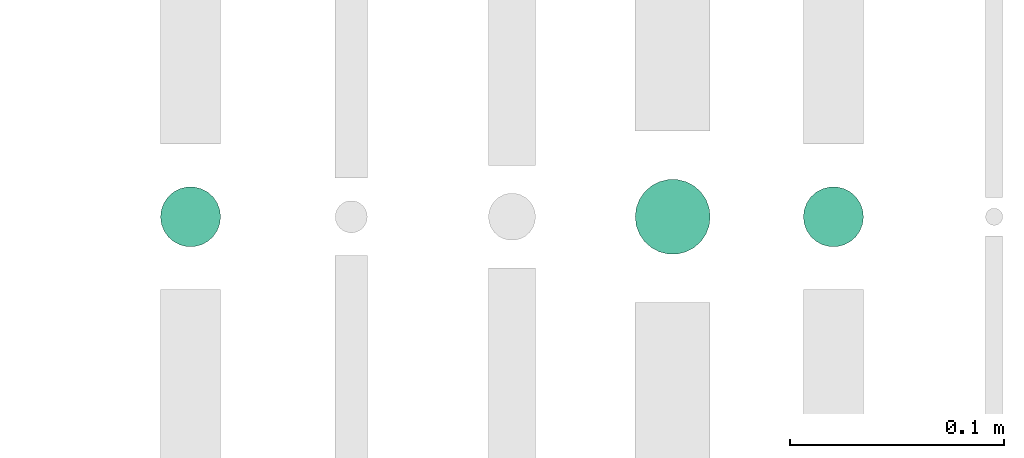
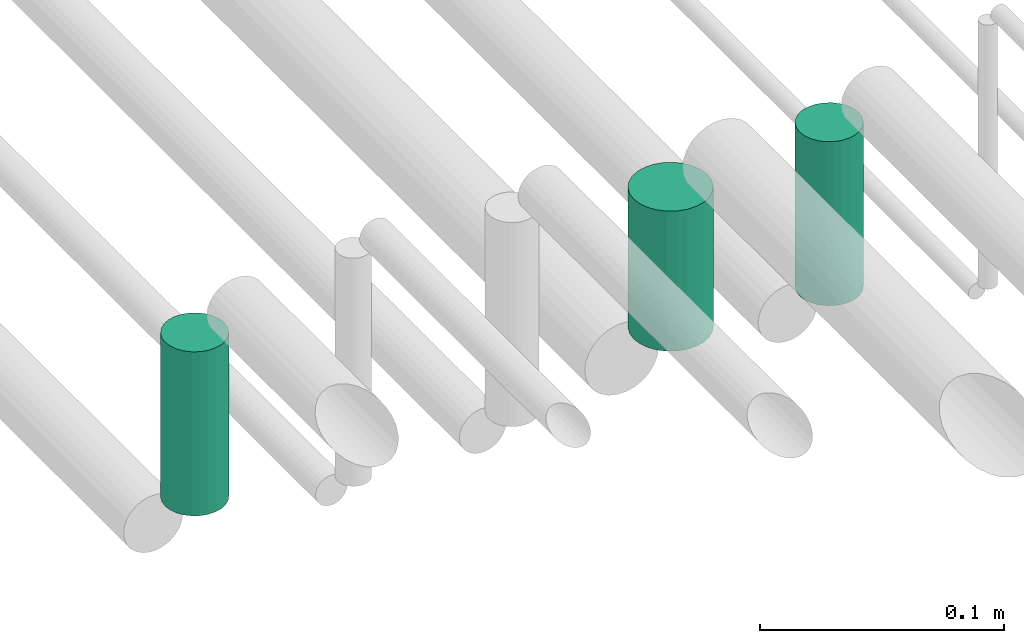
# One storey, part 289 of 331: 3 flow segments.
"""IFC2X3 building model written with IfcOpenShell, lengths in millimetres."""

from ifc_helpers import new_model, entity, si_unit, converted_unit, derived_unit, direction, frame, origin, origin_2d_with_axis, place, context, subcontext, project, spatial, circle, extrude, type_object, element, save


model = new_model("IFC2X3")

# Units and contexts
model_context = context("Model", 3, precision=0.01, world=origin(), true_north=direction((6.12303176911189e-17, 1.0)))
body_context = subcontext(model_context, "Body", "Model", "MODEL_VIEW")
ifc_project = project(units=[si_unit("LENGTHUNIT", "METRE", prefix="MILLI"), si_unit("AREAUNIT", "SQUARE_METRE"), si_unit("VOLUMEUNIT", "CUBIC_METRE"), converted_unit("PLANEANGLEUNIT", "DEGREE", entity("IfcRatioMeasure", 0.0174532925199433), si_unit("PLANEANGLEUNIT", "RADIAN"), dimensions=[0, 0, 0, 0, 0, 0, 0]), si_unit("MASSUNIT", "GRAM", prefix="KILO"), derived_unit("MASSDENSITYUNIT", [(si_unit("MASSUNIT", "GRAM", prefix="KILO"), 1), (si_unit("LENGTHUNIT", "METRE"), -3)]), derived_unit("MOMENTOFINERTIAUNIT", [(si_unit("LENGTHUNIT", "METRE"), 4)]), si_unit("TIMEUNIT", "SECOND"), si_unit("FREQUENCYUNIT", "HERTZ"), si_unit("THERMODYNAMICTEMPERATUREUNIT", "DEGREE_CELSIUS"), derived_unit("THERMALTRANSMITTANCEUNIT", [(si_unit("MASSUNIT", "GRAM", prefix="KILO"), 1), (si_unit("THERMODYNAMICTEMPERATUREUNIT", "KELVIN"), -1), (si_unit("TIMEUNIT", "SECOND"), -3)]), derived_unit("VOLUMETRICFLOWRATEUNIT", [(si_unit("LENGTHUNIT", "METRE"), 3), (si_unit("TIMEUNIT", "SECOND"), -1)]), derived_unit("MASSFLOWRATEUNIT", [(si_unit("MASSUNIT", "GRAM", prefix="KILO"), 1), (si_unit("TIMEUNIT", "SECOND"), -1)]), derived_unit("ROTATIONALFREQUENCYUNIT", [(si_unit("TIMEUNIT", "SECOND"), -1)]), si_unit("ELECTRICCURRENTUNIT", "AMPERE"), si_unit("ELECTRICVOLTAGEUNIT", "VOLT"), si_unit("POWERUNIT", "WATT"), si_unit("FORCEUNIT", "NEWTON", prefix="KILO"), si_unit("ILLUMINANCEUNIT", "LUX"), si_unit("LUMINOUSFLUXUNIT", "LUMEN"), si_unit("LUMINOUSINTENSITYUNIT", "CANDELA"), derived_unit("USERDEFINED", [(si_unit("MASSUNIT", "GRAM", prefix="KILO"), -1), (si_unit("LENGTHUNIT", "METRE"), -2), (si_unit("TIMEUNIT", "SECOND"), 3), (si_unit("LUMINOUSFLUXUNIT", "LUMEN"), 1)]), derived_unit("LINEARVELOCITYUNIT", [(si_unit("LENGTHUNIT", "METRE"), 1), (si_unit("TIMEUNIT", "SECOND"), -1)]), si_unit("PRESSUREUNIT", "PASCAL"), derived_unit("USERDEFINED", [(si_unit("LENGTHUNIT", "METRE"), -2), (si_unit("MASSUNIT", "GRAM", prefix="KILO"), 1), (si_unit("TIMEUNIT", "SECOND"), -2)]), derived_unit("LINEARFORCEUNIT", [(si_unit("MASSUNIT", "GRAM", prefix="KILO"), 1), (si_unit("LENGTHUNIT", "METRE"), 1), (si_unit("TIMEUNIT", "SECOND"), -2), (si_unit("LENGTHUNIT", "METRE"), -1)]), derived_unit("PLANARFORCEUNIT", [(si_unit("MASSUNIT", "GRAM", prefix="KILO"), 1), (si_unit("LENGTHUNIT", "METRE"), 1), (si_unit("TIMEUNIT", "SECOND"), -2), (si_unit("LENGTHUNIT", "METRE"), -2)])], contexts=[model_context])

# Site, building, storey
site_placement = place(None, frame((0.0, -0.00077364408347762, 0.0)))
site = spatial("IfcSite", under=ifc_project, at=site_placement, CompositionType="ELEMENT")
building_placement = place(site_placement, origin())
building = spatial("IfcBuilding", under=site, at=building_placement, CompositionType="ELEMENT")
storey_placement = place(building_placement, origin())
storey = spatial("IfcBuildingStorey", under=building, at=storey_placement, CompositionType="ELEMENT", Elevation=0.0)

# Flow segments
pipe_segment_type = type_object("IfcPipeSegmentType", PredefinedType="NOTDEFINED")
flow_segment_1_placement = place(building_placement, frame((65309.5166309581, 2559.40467691471, 2734.0)))
element("IfcFlowSegment", 1, at=flow_segment_1_placement, inside=storey, type_object=pipe_segment_type, context=body_context, shape_type="SweptSolid", body=[
    extrude(circle(Radius=14.0, at=origin_2d_with_axis()), frame((15.5952722359127, 15.595272235916, 0.0), z_axis=(0.0, 0.0, 1.0), x_axis=(-1.0, 0.0, 0.0)), (0.0, 0.0, 1.0), 82.0000000000572),
])
flow_segment_2_placement = place(building_placement, frame((65531.016630958, 2555.90467691472, 2740.0)))
element("IfcFlowSegment", 2, at=flow_segment_2_placement, inside=storey, type_object=pipe_segment_type, context=body_context, shape_type="SweptSolid", body=[
    extrude(circle(Radius=17.5, at=origin_2d_with_axis()), frame((19.0952722359119, 19.0952722359157, 0.0), z_axis=(0.0, 0.0, 1.0), x_axis=(-1.0, 0.0, 0.0)), (0.0, 0.0, 1.0), 70.0000000000187),
])
flow_segment_3_placement = place(building_placement, frame((65609.5166309581, 2559.40467691472, 2734.0)))
element("IfcFlowSegment", 3, at=flow_segment_3_placement, inside=storey, type_object=pipe_segment_type, context=body_context, shape_type="SweptSolid", body=[
    extrude(circle(Radius=14.0, at=origin_2d_with_axis()), frame((15.5952722359127, 15.595272235916, 0.0), z_axis=(0.0, 0.0, 1.0), x_axis=(-1.0, 0.0, 0.0)), (0.0, 0.0, 1.0), 82.0000000000187),
])

save(model, "model.ifc")
